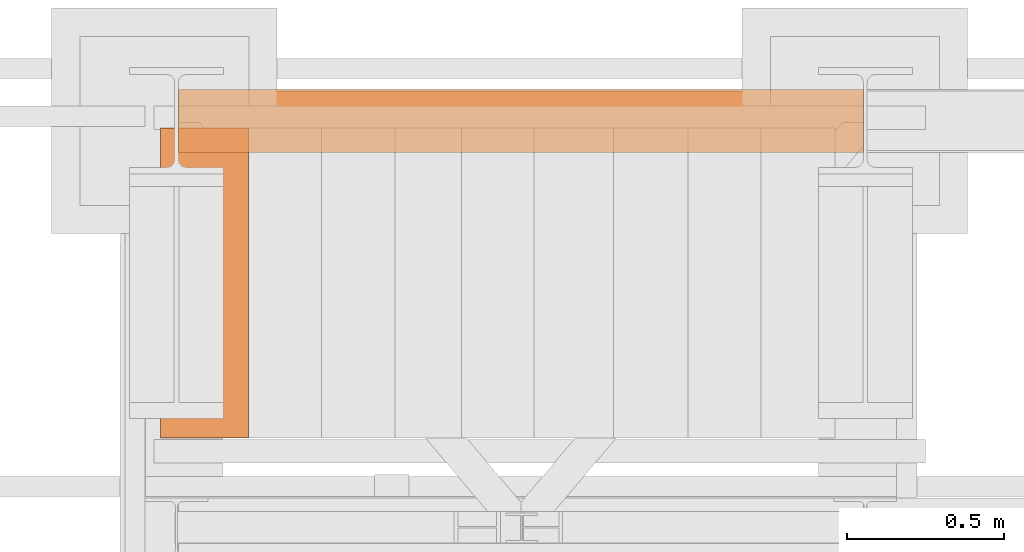
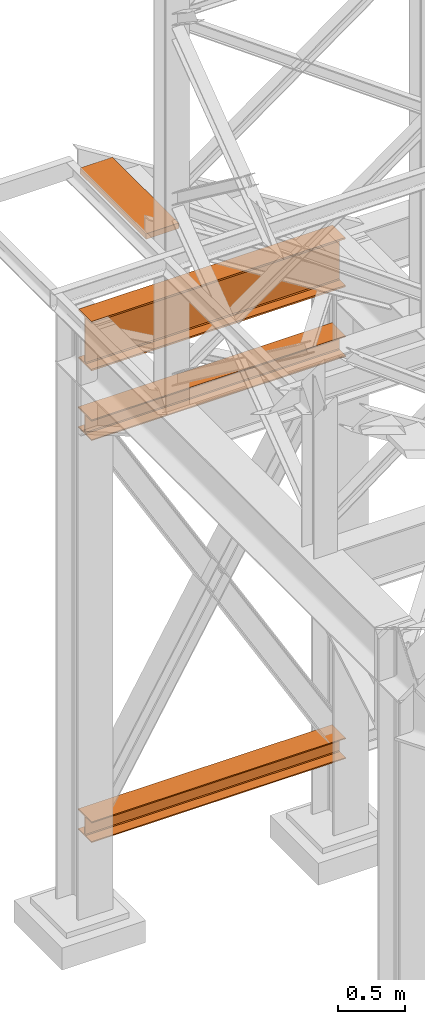
# One storey, part 133 of 208: 4 proxies.
"""IFC2X3 building model written with IfcOpenShell, lengths in millimetres."""

from ifc_helpers import new_model, entity, si_unit, converted_unit, frame, origin, origin_with_axes, place, context, subcontext, project, spatial, faceted_brep, element, save


model = new_model("IFC2X3")

# Units and contexts
model_context = context("Model", 3, precision=1e-05, world=origin())
plan_context = context("Plan", 3, precision=1e-05, world=origin())
body_context = subcontext(model_context, "Body", "Model", "MODEL_VIEW")
ifc_project = project(units=[si_unit("LENGTHUNIT", "METRE", prefix="MILLI"), converted_unit("PLANEANGLEUNIT", "DEGREE", entity("IfcPlaneAngleMeasure", 0.0174532925199433), si_unit("PLANEANGLEUNIT", "RADIAN"), dimensions=[0, 0, 0, 0, 0, 0, 0]), si_unit("AREAUNIT", "SQUARE_METRE"), si_unit("VOLUMEUNIT", "CUBIC_METRE")], contexts=[model_context, plan_context])

# Building, storey
building_placement = place(None, origin())
building = spatial("IfcBuilding", under=ifc_project, at=building_placement, CompositionType="COMPLEX")
storey_placement = place(building_placement, origin_with_axes())
storey = spatial("IfcBuildingStorey", under=building, at=storey_placement, Name="Geschoss", CompositionType="ELEMENT")

# Proxies
proxy_1_placement = place(storey_placement, frame((-3300.745031419177, -12562.57439501763, 544.9900024165573), z_axis=(0.0, 0.0, 1.0), x_axis=(1.0, 0.0, 0.0)))
element("IfcBuildingElementProxy", 1, at=proxy_1_placement, inside=storey, context=body_context, shape_type="Brep", body=[
    faceted_brep([(2188.00999989569, 0.00999999999839929, 190.0100125169755), (2188.00999989569, 200.0100029802306, 190.0100125169755), (2188.00999989569, 200.0100029802306, 180.0100146031381), (2188.00999989569, 121.2600035762771, 180.0100071525575), (2188.00999989569, 111.9441915473326, 178.1454621052743), (2188.00999989569, 105.1245498640819, 171.3258190250398), (2188.00999989569, 103.2600015571697, 162.0100079274179), (2188.00999989569, 103.2600015571697, 28.00999713897716), (2188.00999989569, 105.1245498640819, 18.69418604135524), (2188.00999989569, 111.9441915473326, 11.87454296112071), (2188.00999989569, 121.2600035762771, 10.00999791383754), (2188.00999989569, 200.0100029802306, 10.00999791383754), (2188.00999989569, 200.0100029802306, 0.01000000000010459), (2188.00999989569, 0.00999999999839929, 0.01000000000010459), (2188.00999989569, 0.00999999999839929, 10.00999791383754), (2188.00999989569, 78.75999940395195, 10.00999791383754), (2188.00999989569, 88.07581143289644, 11.87454296112071), (2188.00999989569, 94.89545311614711, 18.69418604135524), (2188.00999989569, 96.7600014230593, 28.00999713897716), (2188.00999989569, 96.7600014230593, 162.0100079274179), (2188.00999989569, 94.89545311614711, 171.3258190250398), (2188.00999989569, 88.07581143289644, 178.1454621052743), (2188.00999989569, 78.75999940395195, 180.0100071525575), (2188.00999989569, 0.00999999999839929, 180.0100146031381), (2188.00999989569, 200.0100029802306, 190.0100125169755), (2188.00999989569, 0.00999999999839929, 190.0100125169755), (0.01000000000021828, 0.01000000000021828, 190.0100125169754), (0.01000000000021828, 200.0100029802325, 190.0100125169754), (2188.00999989569, 200.0100029802306, 180.0100146031381), (2188.00999989569, 200.0100029802306, 190.0100125169755), (0.01000000000021828, 200.0100029802325, 190.0100125169754), (0.01000000000021828, 200.0100029802325, 180.010014603138), (2188.00999989569, 121.2600035762771, 180.0100071525575), (2188.00999989569, 200.0100029802306, 180.0100146031381), (0.01000000000021828, 200.0100029802325, 180.010014603138), (0.01000000000021828, 121.2600035762789, 180.0100071525574), (2188.00999989569, 111.9441915473326, 178.1454621052743), (2188.00999989569, 121.2600035762771, 180.0100071525575), (0.01000000000021828, 121.2600035762789, 180.0100071525574), (0.01000000000021828, 111.9441915473344, 178.1454621052742), (2188.00999989569, 105.1245498640819, 171.3258190250398), (2188.00999989569, 111.9441915473326, 178.1454621052743), (0.01000000000021828, 111.9441915473344, 178.1454621052742), (0.01000000000021828, 105.1245498640838, 171.3258190250397), (2188.00999989569, 103.2600015571697, 162.0100079274179), (2188.00999989569, 105.1245498640819, 171.3258190250398), (0.01000000000021828, 105.1245498640838, 171.3258190250397), (0.01000000000021828, 103.2600015571716, 162.0100079274178), (2188.00999989569, 103.2600015571697, 28.00999713897716), (2188.00999989569, 103.2600015571697, 162.0100079274179), (0.01000000000021828, 103.2600015571716, 162.0100079274178), (0.01000000000021828, 103.2600015571716, 28.00999713897704), (2188.00999989569, 105.1245498640819, 18.69418604135524), (2188.00999989569, 103.2600015571697, 28.00999713897716), (0.01000000000021828, 103.2600015571716, 28.00999713897704), (0.01000000000021828, 105.1245498640838, 18.69418604135512), (2188.00999989569, 111.9441915473326, 11.87454296112071), (2188.00999989569, 105.1245498640819, 18.69418604135524), (0.01000000000021828, 105.1245498640838, 18.69418604135512), (0.01000000000021828, 111.9441915473344, 11.8745429611206), (2188.00999989569, 121.2600035762771, 10.00999791383754), (2188.00999989569, 111.9441915473326, 11.87454296112071), (0.01000000000021828, 111.9441915473344, 11.8745429611206), (0.01000000000021828, 121.2600035762789, 10.00999791383742), (2188.00999989569, 200.0100029802306, 10.00999791383754), (2188.00999989569, 121.2600035762771, 10.00999791383754), (0.01000000000021828, 121.2600035762789, 10.00999791383742), (0.01000000000021828, 200.0100029802325, 10.00999791383742), (2188.00999989569, 200.0100029802306, 0.01000000000010459), (2188.00999989569, 200.0100029802306, 10.00999791383754), (0.01000000000021828, 200.0100029802325, 10.00999791383742), (0.01000000000021828, 200.0100029802325, 0.009999999999990905), (2188.00999989569, 0.00999999999839929, 0.01000000000010459), (2188.00999989569, 200.0100029802306, 0.01000000000010459), (0.01000000000021828, 200.0100029802325, 0.009999999999990905), (0.01000000000021828, 0.01000000000021828, 0.009999999999990905), (2188.00999989569, 0.00999999999839929, 10.00999791383754), (2188.00999989569, 0.00999999999839929, 0.01000000000010459), (0.01000000000021828, 0.01000000000021828, 0.009999999999990905), (0.01000000000021828, 0.01000000000021828, 10.00999791383742), (2188.00999989569, 78.75999940395195, 10.00999791383754), (2188.00999989569, 0.00999999999839929, 10.00999791383754), (0.01000000000021828, 0.01000000000021828, 10.00999791383742), (0.01000000000021828, 78.75999940395377, 10.00999791383742), (2188.00999989569, 88.07581143289644, 11.87454296112071), (2188.00999989569, 78.75999940395195, 10.00999791383754), (0.01000000000021828, 78.75999940395377, 10.00999791383742), (0.01000000000021828, 88.07581143289826, 11.8745429611206), (2188.00999989569, 94.89545311614711, 18.69418604135524), (2188.00999989569, 88.07581143289644, 11.87454296112071), (0.01000000000021828, 88.07581143289826, 11.8745429611206), (0.01000000000021828, 94.89545311614893, 18.69418604135512), (2188.00999989569, 96.7600014230593, 28.00999713897716), (2188.00999989569, 94.89545311614711, 18.69418604135524), (0.01000000000021828, 94.89545311614893, 18.69418604135512), (0.01000000000021828, 96.76000142306111, 28.00999713897704), (2188.00999989569, 96.7600014230593, 162.0100079274179), (2188.00999989569, 96.7600014230593, 28.00999713897716), (0.01000000000021828, 96.76000142306111, 28.00999713897704), (0.01000000000021828, 96.76000142306111, 162.0100079274178), (2188.00999989569, 94.89545311614711, 171.3258190250398), (2188.00999989569, 96.7600014230593, 162.0100079274179), (0.01000000000021828, 96.76000142306111, 162.0100079274178), (0.01000000000021828, 94.89545311614893, 171.3258190250397), (2188.00999989569, 88.07581143289644, 178.1454621052743), (2188.00999989569, 94.89545311614711, 171.3258190250398), (0.01000000000021828, 94.89545311614893, 171.3258190250397), (0.01000000000021828, 88.07581143289826, 178.1454621052742), (2188.00999989569, 78.75999940395195, 180.0100071525575), (2188.00999989569, 88.07581143289644, 178.1454621052743), (0.01000000000021828, 88.07581143289826, 178.1454621052742), (0.01000000000021828, 78.75999940395377, 180.0100071525574), (2188.00999989569, 0.00999999999839929, 180.0100146031381), (2188.00999989569, 78.75999940395195, 180.0100071525575), (0.01000000000021828, 78.75999940395377, 180.0100071525574), (0.01000000000021828, 0.01000000000021828, 180.010014603138), (2188.00999989569, 0.00999999999839929, 190.0100125169755), (2188.00999989569, 0.00999999999839929, 180.0100146031381), (0.01000000000021828, 0.01000000000021828, 180.010014603138), (0.01000000000021828, 0.01000000000021828, 190.0100125169754), (0.01000000000021828, 0.01000000000021828, 190.0100125169754), (0.01000000000021828, 0.01000000000021828, 180.010014603138), (0.01000000000021828, 78.75999940395377, 180.0100071525574), (0.01000000000021828, 88.07581143289826, 178.1454621052742), (0.01000000000021828, 94.89545311614893, 171.3258190250397), (0.01000000000021828, 96.76000142306111, 162.0100079274178), (0.01000000000021828, 96.76000142306111, 28.00999713897704), (0.01000000000021828, 94.89545311614893, 18.69418604135512), (0.01000000000021828, 88.07581143289826, 11.8745429611206), (0.01000000000021828, 78.75999940395377, 10.00999791383742), (0.01000000000021828, 0.01000000000021828, 10.00999791383742), (0.01000000000021828, 0.01000000000021828, 0.009999999999990905), (0.01000000000021828, 200.0100029802325, 0.009999999999990905), (0.01000000000021828, 200.0100029802325, 10.00999791383742), (0.01000000000021828, 121.2600035762789, 10.00999791383742), (0.01000000000021828, 111.9441915473344, 11.8745429611206), (0.01000000000021828, 105.1245498640838, 18.69418604135512), (0.01000000000021828, 103.2600015571716, 28.00999713897704), (0.01000000000021828, 103.2600015571716, 162.0100079274178), (0.01000000000021828, 105.1245498640838, 171.3258190250397), (0.01000000000021828, 111.9441915473344, 178.1454621052742), (0.01000000000021828, 121.2600035762789, 180.0100071525574), (0.01000000000021828, 200.0100029802325, 180.010014603138), (0.01000000000021828, 200.0100029802325, 190.0100125169754)], [[[0, 1, 2, 3, 4, 5, 6, 7, 8, 9, 10, 11, 12, 13, 14, 15, 16, 17, 18, 19, 20, 21, 22, 23]], [[24, 25, 26, 27]], [[28, 29, 30, 31]], [[32, 33, 34, 35]], [[36, 37, 38, 39]], [[40, 41, 42, 43]], [[44, 45, 46, 47]], [[48, 49, 50, 51]], [[52, 53, 54, 55]], [[56, 57, 58, 59]], [[60, 61, 62, 63]], [[64, 65, 66, 67]], [[68, 69, 70, 71]], [[72, 73, 74, 75]], [[76, 77, 78, 79]], [[80, 81, 82, 83]], [[84, 85, 86, 87]], [[88, 89, 90, 91]], [[92, 93, 94, 95]], [[96, 97, 98, 99]], [[100, 101, 102, 103]], [[104, 105, 106, 107]], [[108, 109, 110, 111]], [[112, 113, 114, 115]], [[116, 117, 118, 119]], [[120, 121, 122, 123, 124, 125, 126, 127, 128, 129, 130, 131, 132, 133, 134, 135, 136, 137, 138, 139, 140, 141, 142, 143]]], orient=[[False], [False], [False], [False], [False], [False], [False], [False], [False], [False], [False], [False], [False], [False], [False], [False], [False], [False], [False], [False], [False], [False], [False], [False], [False], [False]]),
])
proxy_2_placement = place(storey_placement, frame((-3300.745031419179, -12557.574399786, 4834.989987483023), z_axis=(0.0, 0.0, 1.0), x_axis=(1.0, 0.0, 0.0)))
element("IfcBuildingElementProxy", 2, at=proxy_2_placement, inside=storey, context=body_context, shape_type="Brep", body=[
    faceted_brep([(2188.009999895692, 0.00999999999839929, 450.0100178813937), (2188.009999895692, 190.0100125169738, 450.0100178813937), (2188.009999895692, 190.0100125169738, 435.4100240564349), (2188.009999895692, 120.7100073045476, 435.4100091552737), (2188.009999895692, 109.8415622657522, 433.2347078418734), (2188.009999895692, 101.8853126263603, 425.2784563398363), (2188.009999895692, 99.71000619068582, 414.4100113010409), (2188.009999895692, 99.71000619068582, 35.60999167919181), (2188.009999895692, 101.8853126263603, 24.74154664039634), (2188.009999895692, 109.8415622657522, 16.78529513835929), (2188.009999895692, 120.7100073045476, 14.60999382495902), (2188.009999895692, 190.0100125169738, 14.60999382495902), (2188.009999895692, 190.0100125169738, 0.01000000000021828), (2188.009999895692, 0.00999999999839929, 0.01000000000021828), (2188.009999895692, 0.00999999999839929, 14.60999382495902), (2188.009999895692, 69.31000521242458, 14.60999382495902), (2188.009999895692, 80.17845025122006, 16.78529513835929), (2188.009999895692, 88.13469989061196, 24.74154664039634), (2188.009999895692, 90.31000632628638, 35.60999167919181), (2188.009999895692, 90.31000632628638, 414.4100113010409), (2188.009999895692, 88.13469989061196, 425.2784563398363), (2188.009999895692, 80.17845025122006, 433.2347078418734), (2188.009999895692, 69.31000521242458, 435.4100091552737), (2188.009999895692, 0.00999999999839929, 435.4100240564349), (2188.009999895692, 190.0100125169738, 450.0100178813937), (2188.009999895692, 0.00999999999839929, 450.0100178813937), (0.01000000000021828, 0.01000000000021828, 450.0100178813937), (0.01000000000021828, 190.0100125169756, 450.0100178813937), (2188.009999895692, 190.0100125169738, 435.4100240564349), (2188.009999895692, 190.0100125169738, 450.0100178813937), (0.01000000000021828, 190.0100125169756, 450.0100178813937), (0.01000000000021828, 190.0100125169756, 435.4100240564349), (2188.009999895692, 120.7100073045476, 435.4100091552737), (2188.009999895692, 190.0100125169738, 435.4100240564349), (0.01000000000021828, 190.0100125169756, 435.4100240564349), (0.01000000000021828, 120.7100073045494, 435.4100091552737), (2188.009999895692, 109.8415622657522, 433.2347078418734), (2188.009999895692, 120.7100073045476, 435.4100091552737), (0.01000000000021828, 120.7100073045494, 435.4100091552737), (0.01000000000021828, 109.841562265754, 433.2347078418734), (2188.009999895692, 101.8853126263603, 425.2784563398363), (2188.009999895692, 109.8415622657522, 433.2347078418734), (0.01000000000021828, 109.841562265754, 433.2347078418734), (0.01000000000021828, 101.8853126263621, 425.2784563398363), (2188.009999895692, 99.71000619068582, 414.4100113010409), (2188.009999895692, 101.8853126263603, 425.2784563398363), (0.01000000000021828, 101.8853126263621, 425.2784563398363), (0.01000000000021828, 99.71000619068764, 414.4100113010409), (2188.009999895692, 99.71000619068582, 35.60999167919181), (2188.009999895692, 99.71000619068582, 414.4100113010409), (0.01000000000021828, 99.71000619068764, 414.4100113010409), (0.01000000000021828, 99.71000619068764, 35.60999167919181), (2188.009999895692, 101.8853126263603, 24.74154664039634), (2188.009999895692, 99.71000619068582, 35.60999167919181), (0.01000000000021828, 99.71000619068764, 35.60999167919181), (0.01000000000021828, 101.8853126263621, 24.74154664039634), (2188.009999895692, 109.8415622657522, 16.78529513835929), (2188.009999895692, 101.8853126263603, 24.74154664039634), (0.01000000000021828, 101.8853126263621, 24.74154664039634), (0.01000000000021828, 109.841562265754, 16.78529513835929), (2188.009999895692, 120.7100073045476, 14.60999382495902), (2188.009999895692, 109.8415622657522, 16.78529513835929), (0.01000000000021828, 109.841562265754, 16.78529513835929), (0.01000000000021828, 120.7100073045494, 14.60999382495902), (2188.009999895692, 190.0100125169738, 14.60999382495902), (2188.009999895692, 120.7100073045476, 14.60999382495902), (0.01000000000021828, 120.7100073045494, 14.60999382495902), (0.01000000000021828, 190.0100125169756, 14.60999382495902), (2188.009999895692, 190.0100125169738, 0.01000000000021828), (2188.009999895692, 190.0100125169738, 14.60999382495902), (0.01000000000021828, 190.0100125169756, 14.60999382495902), (0.01000000000021828, 190.0100125169756, 0.01000000000021828), (2188.009999895692, 0.00999999999839929, 0.01000000000021828), (2188.009999895692, 190.0100125169738, 0.01000000000021828), (0.01000000000021828, 190.0100125169756, 0.01000000000021828), (0.01000000000021828, 0.01000000000021828, 0.01000000000021828), (2188.009999895692, 0.00999999999839929, 14.60999382495902), (2188.009999895692, 0.00999999999839929, 0.01000000000021828), (0.01000000000021828, 0.01000000000021828, 0.01000000000021828), (0.01000000000021828, 0.01000000000021828, 14.60999382495902), (2188.009999895692, 69.31000521242458, 14.60999382495902), (2188.009999895692, 0.00999999999839929, 14.60999382495902), (0.01000000000021828, 0.01000000000021828, 14.60999382495902), (0.01000000000021828, 69.3100052124264, 14.60999382495902), (2188.009999895692, 80.17845025122006, 16.78529513835929), (2188.009999895692, 69.31000521242458, 14.60999382495902), (0.01000000000021828, 69.3100052124264, 14.60999382495902), (0.01000000000021828, 80.17845025122188, 16.78529513835929), (2188.009999895692, 88.13469989061196, 24.74154664039634), (2188.009999895692, 80.17845025122006, 16.78529513835929), (0.01000000000021828, 80.17845025122188, 16.78529513835929), (0.01000000000021828, 88.13469989061377, 24.74154664039634), (2188.009999895692, 90.31000632628638, 35.60999167919181), (2188.009999895692, 88.13469989061196, 24.74154664039634), (0.01000000000021828, 88.13469989061377, 24.74154664039634), (0.01000000000021828, 90.3100063262882, 35.60999167919181), (2188.009999895692, 90.31000632628638, 414.4100113010409), (2188.009999895692, 90.31000632628638, 35.60999167919181), (0.01000000000021828, 90.3100063262882, 35.60999167919181), (0.01000000000021828, 90.3100063262882, 414.4100113010409), (2188.009999895692, 88.13469989061196, 425.2784563398363), (2188.009999895692, 90.31000632628638, 414.4100113010409), (0.01000000000021828, 90.3100063262882, 414.4100113010409), (0.01000000000021828, 88.13469989061377, 425.2784563398363), (2188.009999895692, 80.17845025122006, 433.2347078418734), (2188.009999895692, 88.13469989061196, 425.2784563398363), (0.01000000000021828, 88.13469989061377, 425.2784563398363), (0.01000000000021828, 80.17845025122188, 433.2347078418734), (2188.009999895692, 69.31000521242458, 435.4100091552737), (2188.009999895692, 80.17845025122006, 433.2347078418734), (0.01000000000021828, 80.17845025122188, 433.2347078418734), (0.01000000000021828, 69.3100052124264, 435.4100091552737), (2188.009999895692, 0.00999999999839929, 435.4100240564349), (2188.009999895692, 69.31000521242458, 435.4100091552737), (0.01000000000021828, 69.3100052124264, 435.4100091552737), (0.01000000000021828, 0.01000000000021828, 435.4100240564349), (2188.009999895692, 0.00999999999839929, 450.0100178813937), (2188.009999895692, 0.00999999999839929, 435.4100240564349), (0.01000000000021828, 0.01000000000021828, 435.4100240564349), (0.01000000000021828, 0.01000000000021828, 450.0100178813937), (0.01000000000021828, 0.01000000000021828, 450.0100178813937), (0.01000000000021828, 0.01000000000021828, 435.4100240564349), (0.01000000000021828, 69.3100052124264, 435.4100091552737), (0.01000000000021828, 80.17845025122188, 433.2347078418734), (0.01000000000021828, 88.13469989061377, 425.2784563398363), (0.01000000000021828, 90.3100063262882, 414.4100113010409), (0.01000000000021828, 90.3100063262882, 35.60999167919181), (0.01000000000021828, 88.13469989061377, 24.74154664039634), (0.01000000000021828, 80.17845025122188, 16.78529513835929), (0.01000000000021828, 69.3100052124264, 14.60999382495902), (0.01000000000021828, 0.01000000000021828, 14.60999382495902), (0.01000000000021828, 0.01000000000021828, 0.01000000000021828), (0.01000000000021828, 190.0100125169756, 0.01000000000021828), (0.01000000000021828, 190.0100125169756, 14.60999382495902), (0.01000000000021828, 120.7100073045494, 14.60999382495902), (0.01000000000021828, 109.841562265754, 16.78529513835929), (0.01000000000021828, 101.8853126263621, 24.74154664039634), (0.01000000000021828, 99.71000619068764, 35.60999167919181), (0.01000000000021828, 99.71000619068764, 414.4100113010409), (0.01000000000021828, 101.8853126263621, 425.2784563398363), (0.01000000000021828, 109.841562265754, 433.2347078418734), (0.01000000000021828, 120.7100073045494, 435.4100091552737), (0.01000000000021828, 190.0100125169756, 435.4100240564349), (0.01000000000021828, 190.0100125169756, 450.0100178813937)], [[[0, 1, 2, 3, 4, 5, 6, 7, 8, 9, 10, 11, 12, 13, 14, 15, 16, 17, 18, 19, 20, 21, 22, 23]], [[24, 25, 26, 27]], [[28, 29, 30, 31]], [[32, 33, 34, 35]], [[36, 37, 38, 39]], [[40, 41, 42, 43]], [[44, 45, 46, 47]], [[48, 49, 50, 51]], [[52, 53, 54, 55]], [[56, 57, 58, 59]], [[60, 61, 62, 63]], [[64, 65, 66, 67]], [[68, 69, 70, 71]], [[72, 73, 74, 75]], [[76, 77, 78, 79]], [[80, 81, 82, 83]], [[84, 85, 86, 87]], [[88, 89, 90, 91]], [[92, 93, 94, 95]], [[96, 97, 98, 99]], [[100, 101, 102, 103]], [[104, 105, 106, 107]], [[108, 109, 110, 111]], [[112, 113, 114, 115]], [[116, 117, 118, 119]], [[120, 121, 122, 123, 124, 125, 126, 127, 128, 129, 130, 131, 132, 133, 134, 135, 136, 137, 138, 139, 140, 141, 142, 143]]], orient=[[False], [False], [False], [False], [False], [False], [False], [False], [False], [False], [False], [False], [False], [False], [False], [False], [False], [False], [False], [False], [False], [False], [False], [False], [False], [False]]),
])
proxy_3_placement = place(storey_placement, frame((-3300.745031419177, -12562.57439501764, 4202.989992847441), z_axis=(0.0, 0.0, 1.0), x_axis=(1.0, 0.0, 0.0)))
element("IfcBuildingElementProxy", 3, at=proxy_3_placement, inside=storey, context=body_context, shape_type="Brep", body=[
    faceted_brep([(2188.00999989569, 0.01000000000021828, 190.0100125169756), (2188.00999989569, 200.0100029802325, 190.0100125169756), (2188.00999989569, 200.0100029802325, 180.0100146031382), (2188.00999989569, 121.2600035762789, 180.0100071525576), (2188.00999989569, 111.9441915473344, 178.1454621052744), (2188.00999989569, 105.1245498640838, 171.3258190250399), (2188.00999989569, 103.2600015571716, 162.010007927418), (2188.00999989569, 103.2600015571716, 28.00999713897727), (2188.00999989569, 105.1245498640838, 18.69418604135535), (2188.00999989569, 111.9441915473344, 11.87454296112082), (2188.00999989569, 121.2600035762789, 10.00999791383765), (2188.00999989569, 200.0100029802325, 10.00999791383765), (2188.00999989569, 200.0100029802325, 0.01000000000021828), (2188.00999989569, 0.01000000000021828, 0.01000000000021828), (2188.00999989569, 0.01000000000021828, 10.00999791383765), (2188.00999989569, 78.75999940395377, 10.00999791383765), (2188.00999989569, 88.07581143289826, 11.87454296112082), (2188.00999989569, 94.89545311614893, 18.69418604135535), (2188.00999989569, 96.76000142306111, 28.00999713897727), (2188.00999989569, 96.76000142306111, 162.010007927418), (2188.00999989569, 94.89545311614893, 171.3258190250399), (2188.00999989569, 88.07581143289826, 178.1454621052744), (2188.00999989569, 78.75999940395377, 180.0100071525576), (2188.00999989569, 0.01000000000021828, 180.0100146031382), (2188.00999989569, 200.0100029802325, 190.0100125169756), (2188.00999989569, 0.01000000000021828, 190.0100125169756), (0.01000000000021828, 0.01000000000021828, 190.0100125169756), (0.01000000000021828, 200.0100029802325, 190.0100125169756), (2188.00999989569, 200.0100029802325, 180.0100146031382), (2188.00999989569, 200.0100029802325, 190.0100125169756), (0.01000000000021828, 200.0100029802325, 190.0100125169756), (0.01000000000021828, 200.0100029802325, 180.0100146031382), (2188.00999989569, 121.2600035762789, 180.0100071525576), (2188.00999989569, 200.0100029802325, 180.0100146031382), (0.01000000000021828, 200.0100029802325, 180.0100146031382), (0.01000000000021828, 121.2600035762789, 180.0100071525576), (2188.00999989569, 111.9441915473344, 178.1454621052744), (2188.00999989569, 121.2600035762789, 180.0100071525576), (0.01000000000021828, 121.2600035762789, 180.0100071525576), (0.01000000000021828, 111.9441915473344, 178.1454621052744), (2188.00999989569, 105.1245498640838, 171.3258190250399), (2188.00999989569, 111.9441915473344, 178.1454621052744), (0.01000000000021828, 111.9441915473344, 178.1454621052744), (0.01000000000021828, 105.1245498640838, 171.3258190250399), (2188.00999989569, 103.2600015571716, 162.010007927418), (2188.00999989569, 105.1245498640838, 171.3258190250399), (0.01000000000021828, 105.1245498640838, 171.3258190250399), (0.01000000000021828, 103.2600015571716, 162.010007927418), (2188.00999989569, 103.2600015571716, 28.00999713897727), (2188.00999989569, 103.2600015571716, 162.010007927418), (0.01000000000021828, 103.2600015571716, 162.010007927418), (0.01000000000021828, 103.2600015571716, 28.00999713897727), (2188.00999989569, 105.1245498640838, 18.69418604135535), (2188.00999989569, 103.2600015571716, 28.00999713897727), (0.01000000000021828, 103.2600015571716, 28.00999713897727), (0.01000000000021828, 105.1245498640838, 18.69418604135535), (2188.00999989569, 111.9441915473344, 11.87454296112082), (2188.00999989569, 105.1245498640838, 18.69418604135535), (0.01000000000021828, 105.1245498640838, 18.69418604135535), (0.01000000000021828, 111.9441915473344, 11.87454296112082), (2188.00999989569, 121.2600035762789, 10.00999791383765), (2188.00999989569, 111.9441915473344, 11.87454296112082), (0.01000000000021828, 111.9441915473344, 11.87454296112082), (0.01000000000021828, 121.2600035762789, 10.00999791383765), (2188.00999989569, 200.0100029802325, 10.00999791383765), (2188.00999989569, 121.2600035762789, 10.00999791383765), (0.01000000000021828, 121.2600035762789, 10.00999791383765), (0.01000000000021828, 200.0100029802325, 10.00999791383765), (2188.00999989569, 200.0100029802325, 0.01000000000021828), (2188.00999989569, 200.0100029802325, 10.00999791383765), (0.01000000000021828, 200.0100029802325, 10.00999791383765), (0.01000000000021828, 200.0100029802325, 0.01000000000021828), (2188.00999989569, 0.01000000000021828, 0.01000000000021828), (2188.00999989569, 200.0100029802325, 0.01000000000021828), (0.01000000000021828, 200.0100029802325, 0.01000000000021828), (0.01000000000021828, 0.01000000000021828, 0.01000000000021828), (2188.00999989569, 0.01000000000021828, 10.00999791383765), (2188.00999989569, 0.01000000000021828, 0.01000000000021828), (0.01000000000021828, 0.01000000000021828, 0.01000000000021828), (0.01000000000021828, 0.01000000000021828, 10.00999791383765), (2188.00999989569, 78.75999940395377, 10.00999791383765), (2188.00999989569, 0.01000000000021828, 10.00999791383765), (0.01000000000021828, 0.01000000000021828, 10.00999791383765), (0.01000000000021828, 78.75999940395377, 10.00999791383765), (2188.00999989569, 88.07581143289826, 11.87454296112082), (2188.00999989569, 78.75999940395377, 10.00999791383765), (0.01000000000021828, 78.75999940395377, 10.00999791383765), (0.01000000000021828, 88.07581143289826, 11.87454296112082), (2188.00999989569, 94.89545311614893, 18.69418604135535), (2188.00999989569, 88.07581143289826, 11.87454296112082), (0.01000000000021828, 88.07581143289826, 11.87454296112082), (0.01000000000021828, 94.89545311614893, 18.69418604135535), (2188.00999989569, 96.76000142306111, 28.00999713897727), (2188.00999989569, 94.89545311614893, 18.69418604135535), (0.01000000000021828, 94.89545311614893, 18.69418604135535), (0.01000000000021828, 96.76000142306111, 28.00999713897727), (2188.00999989569, 96.76000142306111, 162.010007927418), (2188.00999989569, 96.76000142306111, 28.00999713897727), (0.01000000000021828, 96.76000142306111, 28.00999713897727), (0.01000000000021828, 96.76000142306111, 162.010007927418), (2188.00999989569, 94.89545311614893, 171.3258190250399), (2188.00999989569, 96.76000142306111, 162.010007927418), (0.01000000000021828, 96.76000142306111, 162.010007927418), (0.01000000000021828, 94.89545311614893, 171.3258190250399), (2188.00999989569, 88.07581143289826, 178.1454621052744), (2188.00999989569, 94.89545311614893, 171.3258190250399), (0.01000000000021828, 94.89545311614893, 171.3258190250399), (0.01000000000021828, 88.07581143289826, 178.1454621052744), (2188.00999989569, 78.75999940395377, 180.0100071525576), (2188.00999989569, 88.07581143289826, 178.1454621052744), (0.01000000000021828, 88.07581143289826, 178.1454621052744), (0.01000000000021828, 78.75999940395377, 180.0100071525576), (2188.00999989569, 0.01000000000021828, 180.0100146031382), (2188.00999989569, 78.75999940395377, 180.0100071525576), (0.01000000000021828, 78.75999940395377, 180.0100071525576), (0.01000000000021828, 0.01000000000021828, 180.0100146031382), (2188.00999989569, 0.01000000000021828, 190.0100125169756), (2188.00999989569, 0.01000000000021828, 180.0100146031382), (0.01000000000021828, 0.01000000000021828, 180.0100146031382), (0.01000000000021828, 0.01000000000021828, 190.0100125169756), (0.01000000000021828, 0.01000000000021828, 190.0100125169756), (0.01000000000021828, 0.01000000000021828, 180.0100146031382), (0.01000000000021828, 78.75999940395377, 180.0100071525576), (0.01000000000021828, 88.07581143289826, 178.1454621052744), (0.01000000000021828, 94.89545311614893, 171.3258190250399), (0.01000000000021828, 96.76000142306111, 162.010007927418), (0.01000000000021828, 96.76000142306111, 28.00999713897727), (0.01000000000021828, 94.89545311614893, 18.69418604135535), (0.01000000000021828, 88.07581143289826, 11.87454296112082), (0.01000000000021828, 78.75999940395377, 10.00999791383765), (0.01000000000021828, 0.01000000000021828, 10.00999791383765), (0.01000000000021828, 0.01000000000021828, 0.01000000000021828), (0.01000000000021828, 200.0100029802325, 0.01000000000021828), (0.01000000000021828, 200.0100029802325, 10.00999791383765), (0.01000000000021828, 121.2600035762789, 10.00999791383765), (0.01000000000021828, 111.9441915473344, 11.87454296112082), (0.01000000000021828, 105.1245498640838, 18.69418604135535), (0.01000000000021828, 103.2600015571716, 28.00999713897727), (0.01000000000021828, 103.2600015571716, 162.010007927418), (0.01000000000021828, 105.1245498640838, 171.3258190250399), (0.01000000000021828, 111.9441915473344, 178.1454621052744), (0.01000000000021828, 121.2600035762789, 180.0100071525576), (0.01000000000021828, 200.0100029802325, 180.0100146031382), (0.01000000000021828, 200.0100029802325, 190.0100125169756)], [[[0, 1, 2, 3, 4, 5, 6, 7, 8, 9, 10, 11, 12, 13, 14, 15, 16, 17, 18, 19, 20, 21, 22, 23]], [[24, 25, 26, 27]], [[28, 29, 30, 31]], [[32, 33, 34, 35]], [[36, 37, 38, 39]], [[40, 41, 42, 43]], [[44, 45, 46, 47]], [[48, 49, 50, 51]], [[52, 53, 54, 55]], [[56, 57, 58, 59]], [[60, 61, 62, 63]], [[64, 65, 66, 67]], [[68, 69, 70, 71]], [[72, 73, 74, 75]], [[76, 77, 78, 79]], [[80, 81, 82, 83]], [[84, 85, 86, 87]], [[88, 89, 90, 91]], [[92, 93, 94, 95]], [[96, 97, 98, 99]], [[100, 101, 102, 103]], [[104, 105, 106, 107]], [[108, 109, 110, 111]], [[112, 113, 114, 115]], [[116, 117, 118, 119]], [[120, 121, 122, 123, 124, 125, 126, 127, 128, 129, 130, 131, 132, 133, 134, 135, 136, 137, 138, 139, 140, 141, 142, 143]]], orient=[[False], [False], [False], [False], [False], [False], [False], [False], [False], [False], [False], [False], [False], [False], [False], [False], [False], [False], [False], [False], [False], [False], [False], [False], [False], [False]]),
])
proxy_4_placement = place(storey_placement, frame((-3357.552590043645, -13474.7262510599, 6610.759817929117), z_axis=(0.0, 0.0, 1.0), x_axis=(1.0, 0.0, 0.0)))
element("IfcBuildingElementProxy", 4, at=proxy_4_placement, inside=storey, context=body_context, shape_type="Brep", body=[
    faceted_brep([(0.01000000000021828, 0.01000000000021828, 0.01000000000021828), (280.2746556316179, 0.01000000000021828, 0.01000000000021828), (280.2746556316179, 988.9080206708586, 0.01000000000021828), (0.01000000000021828, 988.9080206708586, 0.01000000000021828), (280.2746556316179, 0.01000000000021828, 50.01000000000022), (0.01000000000021828, 0.01000000000021828, 50.01000000000022), (0.01000000000021828, 988.9080206708586, 50.01000000000022), (280.2746556316179, 988.9080206708586, 50.01000000000022), (280.2746556316179, 0.01000000000021828, 0.01000000000021828), (0.01000000000021828, 0.01000000000021828, 0.01000000000021828), (0.01000000000021828, 0.01000000000021828, 50.01000000000022), (280.2746556316179, 0.01000000000021828, 50.01000000000022), (280.2746556316179, 988.9080206708586, 0.01000000000021828), (280.2746556316179, 0.01000000000021828, 0.01000000000021828), (280.2746556316179, 0.01000000000021828, 50.01000000000022), (280.2746556316179, 988.9080206708586, 50.01000000000022), (0.01000000000021828, 988.9080206708586, 0.01000000000021828), (280.2746556316179, 988.9080206708586, 0.01000000000021828), (280.2746556316179, 988.9080206708586, 50.01000000000022), (0.01000000000021828, 988.9080206708586, 50.01000000000022), (0.01000000000021828, 0.01000000000021828, 0.01000000000021828), (0.01000000000021828, 988.9080206708586, 0.01000000000021828), (0.01000000000021828, 988.9080206708586, 50.01000000000022), (0.01000000000021828, 0.01000000000021828, 50.01000000000022)], [[[0, 1, 2, 3]], [[4, 5, 6, 7]], [[8, 9, 10, 11]], [[12, 13, 14, 15]], [[16, 17, 18, 19]], [[20, 21, 22, 23]]], orient=[[False], [False], [False], [False], [False], [False]]),
])

save(model, "model.ifc")
